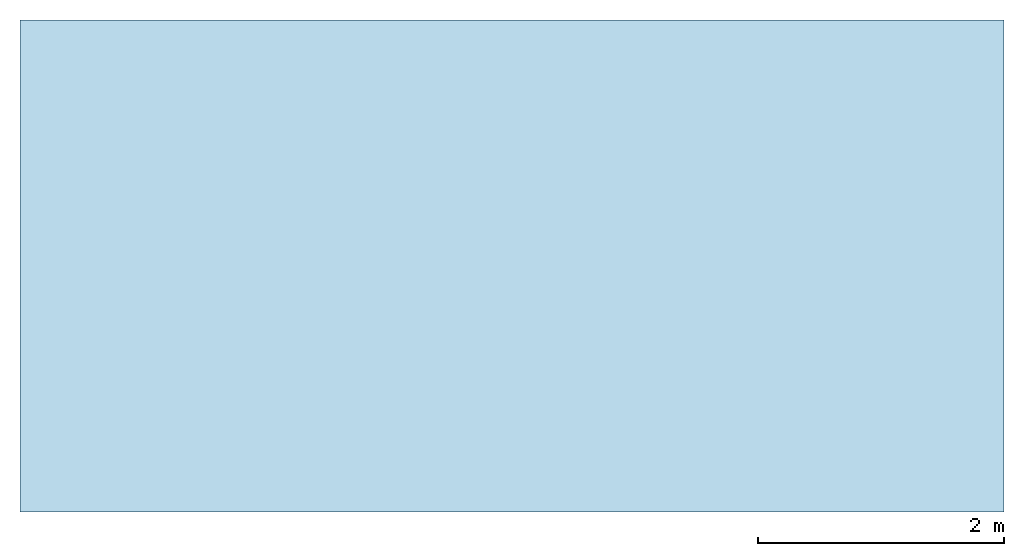
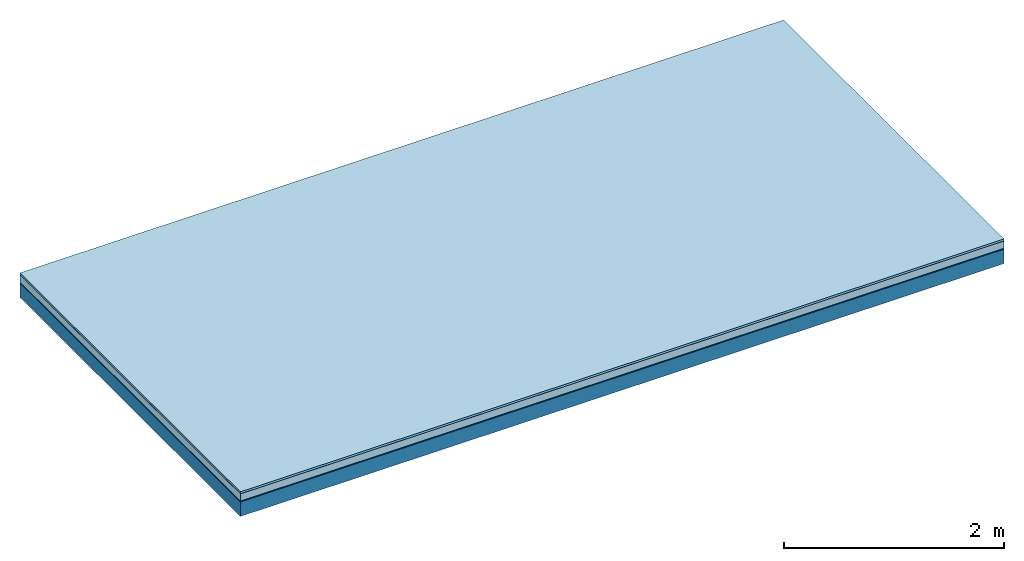
# One storey: 5 plates, 1 member, 1 element without a shape of its own.
"""IFC4 building model written with IfcOpenShell, lengths in metres."""

from ifc_helpers import new_model, si_unit, derived_unit, direction, frame, frame_2d, origin, origin_with_axes, place, context, project, spatial, rectangle, extrude, material, layer, layer_set, type_object, element, aggregate, save


model = new_model("IFC4")

# Units and contexts
plan_context = context("Plan", 3, precision=1e-05, world=origin(), true_north=direction((0.0, 1.0)))
model_context = context("Model", 3, precision=1e-05, world=origin(), true_north=direction((0.0, 1.0)))
ifc_project = project(units=[si_unit("LENGTHUNIT", "METRE"), derived_unit("SOUNDPRESSUREUNIT", [(si_unit("PRESSUREUNIT", "PASCAL", prefix="MICRO"), 0)]), si_unit("ENERGYUNIT", "JOULE", prefix="MEGA"), si_unit("MASSUNIT", "GRAM", prefix="KILO"), derived_unit("THERMALTRANSMITTANCEUNIT", [(si_unit("POWERUNIT", "WATT"), 1), (si_unit("AREAUNIT", "SQUARE_METRE"), -1), (si_unit("THERMODYNAMICTEMPERATUREUNIT", "KELVIN"), -1)]), derived_unit("AREADENSITYUNIT", [(si_unit("MASSUNIT", "GRAM", prefix="KILO"), 1), (si_unit("AREAUNIT", "SQUARE_METRE"), -1)]), derived_unit("USERDEFINED", [(si_unit("ENERGYUNIT", "JOULE", prefix="MEGA"), 1), (si_unit("AREAUNIT", "SQUARE_METRE"), -1)])], contexts=[plan_context, model_context])

# Site, building, storey
site = spatial("IfcSite", under=ifc_project)
building_placement = place(None, origin())
building = spatial("IfcBuilding", under=site, at=building_placement)
storey_placement = place(building_placement, origin())
storey = spatial("IfcBuildingStorey", under=building, at=storey_placement)

# Slab, member, plates
ifc_material_1 = material(Name="with tongue and groove", Category="07.009")
ifc_layer_1 = layer(ifc_material_1, 0.022, Name="Flooring")
ifc_material_2 = material(Category="09.006")
ifc_layer_2 = layer(ifc_material_2, 0.0005, Name="layer")
ifc_material_3 = material(Category="07.011")
ifc_layer_3 = layer(ifc_material_3, 0.08, Name="On-material")
ifc_material_4 = material(Name="Wood fiber generic product", Category="10.009")
ifc_layer_4 = layer(ifc_material_4, 0.01, Name="Impact sound insulation")
ifc_material_5 = material(Name="protection", Category="09.007")
ifc_layer_5 = layer(ifc_material_5, 0.0005, Name="Sub-floor")
ifc_material_6 = material(Name="no composite action")
ifc_layer_6 = layer(ifc_material_6, 0.0, Name="Bond")
ifc_layer_7 = layer(None, 0.16, Name="Supporting structure")
ifc_layer_set = layer_set([ifc_layer_1, ifc_layer_2, ifc_layer_3, ifc_layer_4, ifc_layer_5, ifc_layer_6, ifc_layer_7])
slab_type = type_object("IfcSlabType", Name="A2017", PredefinedType="NOTDEFINED", material=ifc_layer_set)
slab_placement = place(None, frame((0.0, 0.0, 0.0), z_axis=(0.0, 0.0, -1.0), x_axis=(1.0, 0.0, 0.0)))
slab = element("IfcSlab", 1, at=slab_placement, inside=storey, type_object=slab_type, material=ifc_layer_set, Name="Slab #1")
ifc_material_7 = material(Name="Solid timber panel")
member_placement = place(slab_placement, origin())
member = element("IfcMember", 2, at=member_placement, material=ifc_material_7, Name="Supporting structure", context=plan_context, shape_type="SweptSolid", body=[
    extrude(rectangle(XDim=1.0, YDim=0.16, at=frame_2d((0.5, 0.08), x_axis=(1.0, 0.0))), frame((0.0, 4.0, 0.113), z_axis=(0.0, -1.0, 0.0), x_axis=(1.0, 0.0, 0.0)), (0.0, 0.0, 1.0), 4.0),
    extrude(rectangle(XDim=1.0, YDim=0.16, at=frame_2d((0.5, 0.08), x_axis=(1.0, 0.0))), frame((1.0, 4.0, 0.113), z_axis=(0.0, -1.0, 0.0), x_axis=(1.0, 0.0, 0.0)), (0.0, 0.0, 1.0), 4.0),
    extrude(rectangle(XDim=1.0, YDim=0.16, at=frame_2d((0.5, 0.08), x_axis=(1.0, 0.0))), frame((2.0, 4.0, 0.113), z_axis=(0.0, -1.0, 0.0), x_axis=(1.0, 0.0, 0.0)), (0.0, 0.0, 1.0), 4.0),
    extrude(rectangle(XDim=1.0, YDim=0.16, at=frame_2d((0.5, 0.08), x_axis=(1.0, 0.0))), frame((3.0, 4.0, 0.113), z_axis=(0.0, -1.0, 0.0), x_axis=(1.0, 0.0, 0.0)), (0.0, 0.0, 1.0), 4.0),
    extrude(rectangle(XDim=1.0, YDim=0.16, at=frame_2d((0.5, 0.08), x_axis=(1.0, 0.0))), frame((4.0, 4.0, 0.113), z_axis=(0.0, -1.0, 0.0), x_axis=(1.0, 0.0, 0.0)), (0.0, 0.0, 1.0), 4.0),
    extrude(rectangle(XDim=1.0, YDim=0.16, at=frame_2d((0.5, 0.08), x_axis=(1.0, 0.0))), frame((5.0, 4.0, 0.113), z_axis=(0.0, -1.0, 0.0), x_axis=(1.0, 0.0, 0.0)), (0.0, 0.0, 1.0), 4.0),
    extrude(rectangle(XDim=1.0, YDim=0.16, at=frame_2d((0.5, 0.08), x_axis=(1.0, 0.0))), frame((6.0, 4.0, 0.113), z_axis=(0.0, -1.0, 0.0), x_axis=(1.0, 0.0, 0.0)), (0.0, 0.0, 1.0), 4.0),
    extrude(rectangle(XDim=1.0, YDim=0.16, at=frame_2d((0.5, 0.08), x_axis=(1.0, 0.0))), frame((7.0, 4.0, 0.113), z_axis=(0.0, -1.0, 0.0), x_axis=(1.0, 0.0, 0.0)), (0.0, 0.0, 1.0), 4.0),
])
plate_1_placement = place(slab_placement, origin())
plate_1 = element("IfcPlate", 3, at=plate_1_placement, material=ifc_material_1, Name="Flooring", context=plan_context, shape_type="SweptSolid", body=[
    extrude(rectangle(XDim=8.0, YDim=4.0, at=frame_2d((4.0, 2.0), x_axis=(1.0, 0.0))), origin_with_axes(), (0.0, 0.0, 1.0), 0.022),
])
plate_2_placement = place(slab_placement, origin())
plate_2 = element("IfcPlate", 4, at=plate_2_placement, material=ifc_material_2, Name="layer", context=plan_context, shape_type="SweptSolid", body=[
    extrude(rectangle(XDim=8.0, YDim=4.0, at=frame_2d((4.0, 2.0), x_axis=(1.0, 0.0))), frame((0.0, 0.0, 0.022), z_axis=(0.0, 0.0, 1.0), x_axis=(1.0, 0.0, 0.0)), (0.0, 0.0, 1.0), 0.0005),
])
plate_3_placement = place(slab_placement, origin())
plate_3 = element("IfcPlate", 5, at=plate_3_placement, material=ifc_material_3, Name="On-material", context=plan_context, shape_type="SweptSolid", body=[
    extrude(rectangle(XDim=8.0, YDim=4.0, at=frame_2d((4.0, 2.0), x_axis=(1.0, 0.0))), frame((0.0, 0.0, 0.0225), z_axis=(0.0, 0.0, 1.0), x_axis=(1.0, 0.0, 0.0)), (0.0, 0.0, 1.0), 0.08),
])
plate_4_placement = place(slab_placement, origin())
plate_4 = element("IfcPlate", 6, at=plate_4_placement, material=ifc_material_4, Name="Impact sound insulation", context=plan_context, shape_type="SweptSolid", body=[
    extrude(rectangle(XDim=8.0, YDim=4.0, at=frame_2d((4.0, 2.0), x_axis=(1.0, 0.0))), frame((0.0, 0.0, 0.1025), z_axis=(0.0, 0.0, 1.0), x_axis=(1.0, 0.0, 0.0)), (0.0, 0.0, 1.0), 0.01),
])
plate_5_placement = place(slab_placement, origin())
plate_5 = element("IfcPlate", 7, at=plate_5_placement, material=ifc_material_5, Name="Sub-floor", context=plan_context, shape_type="SweptSolid", body=[
    extrude(rectangle(XDim=8.0, YDim=4.0, at=frame_2d((4.0, 2.0), x_axis=(1.0, 0.0))), frame((0.0, 0.0, 0.1125), z_axis=(0.0, 0.0, 1.0), x_axis=(1.0, 0.0, 0.0)), (0.0, 0.0, 1.0), 0.0005),
])
aggregate(slab, [plate_1, plate_2, plate_3, plate_4, plate_5, member])

save(model, "model.ifc")
